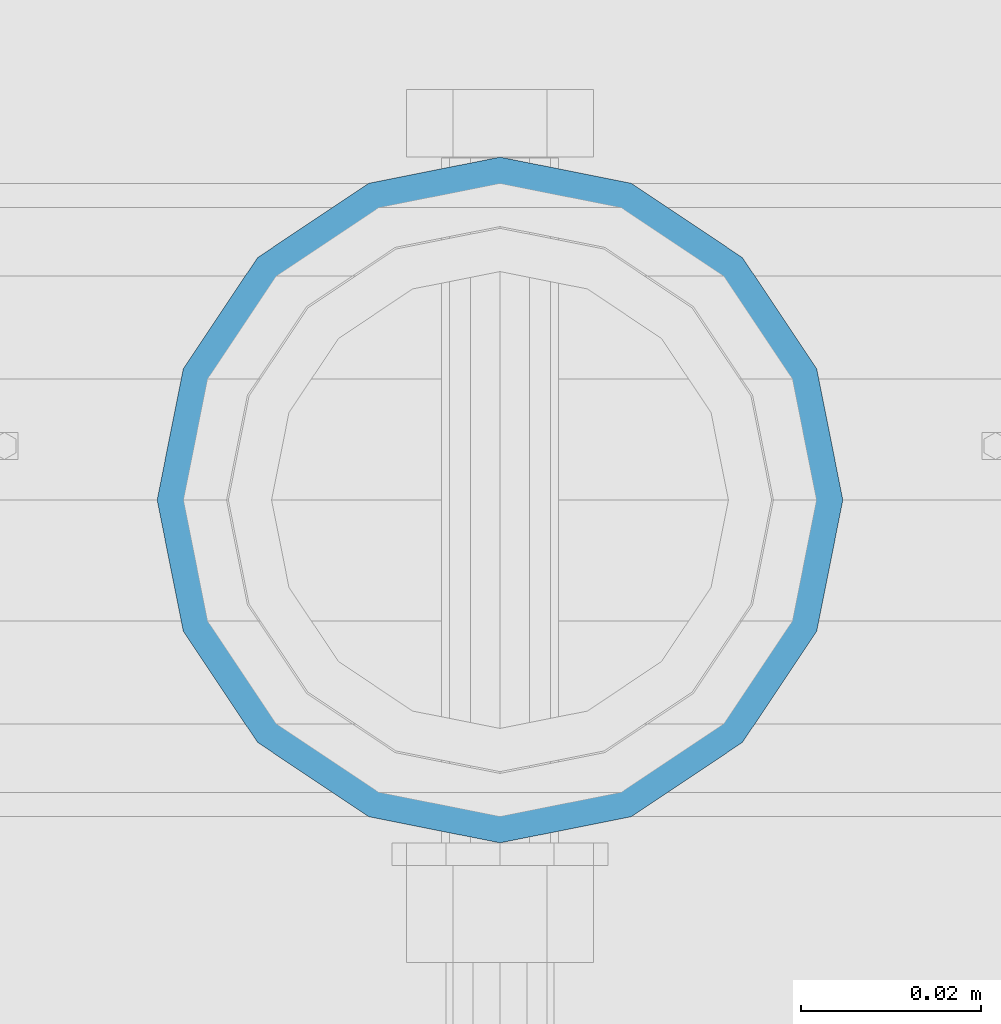
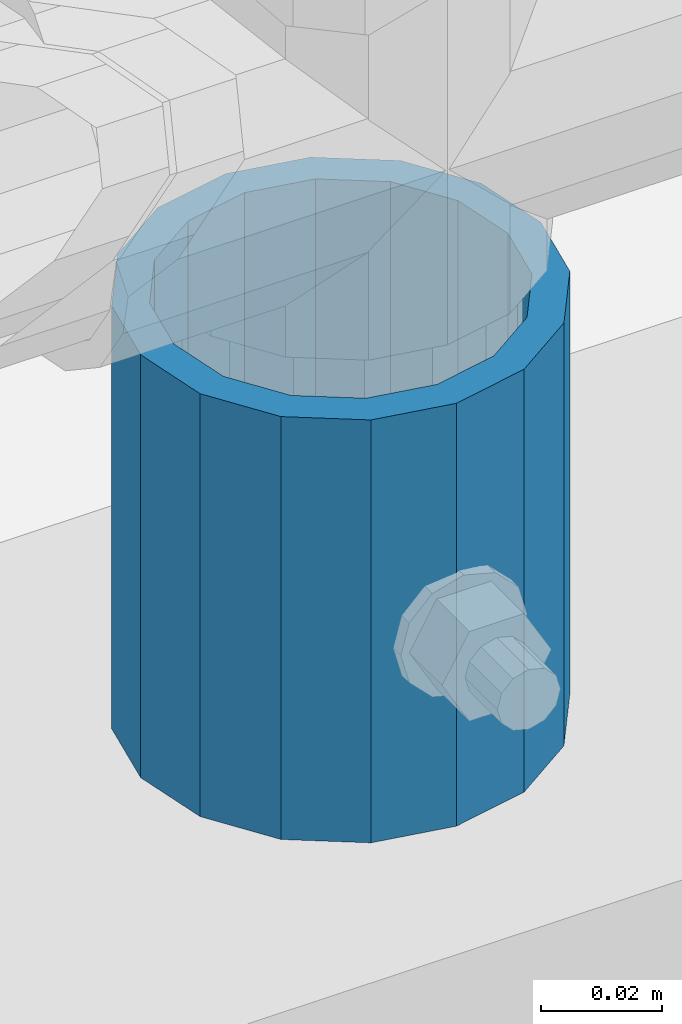
# One storey, part 93 of 242: 1 column.
"""IFC2X3 building model written with IfcOpenShell, lengths in millimetres."""

from ifc_helpers import new_model, si_unit, frame, origin_with_axes, place, context, subcontext, project, spatial, faceted_brep, material, type_object, element, save


model = new_model("IFC2X3")

# Units and contexts
model_context = context("Model", 3, precision=1e-05, world=origin_with_axes())
body_context = subcontext(model_context, "Body", "Model", "MODEL_VIEW")
ifc_project = project(units=[si_unit("LENGTHUNIT", "METRE", prefix="MILLI"), si_unit("AREAUNIT", "SQUARE_METRE"), si_unit("VOLUMEUNIT", "CUBIC_METRE"), si_unit("MASSUNIT", "GRAM", prefix="KILO"), si_unit("TIMEUNIT", "SECOND"), si_unit("PLANEANGLEUNIT", "RADIAN"), si_unit("SOLIDANGLEUNIT", "STERADIAN"), si_unit("THERMODYNAMICTEMPERATUREUNIT", "DEGREE_CELSIUS"), si_unit("LUMINOUSINTENSITYUNIT", "LUMEN")], contexts=[model_context])

# Site, building, storey
site_placement = place(None, origin_with_axes())
site = spatial("IfcSite", under=ifc_project, at=site_placement, CompositionType="ELEMENT")
building_placement = place(site_placement, origin_with_axes())
building = spatial("IfcBuilding", under=site, at=building_placement, Name="Standard", CompositionType="ELEMENT")
storey_placement = place(building_placement, origin_with_axes())
storey = spatial("IfcBuildingStorey", under=building, at=storey_placement, Name="Undefined", CompositionType="ELEMENT", Elevation=0.0)

# Column
ifc_material = material()
column_type = type_object("IfcColumnType", PredefinedType="NOTDEFINED")
column_placement = place(storey_placement, frame((-28765.0, -19335.5, 168.02), z_axis=(0.0, 1.0, 0.0), x_axis=(0.0, 0.0, 1.0)))
element("IfcColumn", 1, at=column_placement, inside=storey, type_object=column_type, material=ifc_material, context=body_context, shape_type="Brep", body=[
    faceted_brep([(0.0, -31.75, 0.0), (0.0, -29.3331751572332, 12.1501989775934), (85.0, -29.3331751572332, 12.1501989775934), (85.0, -31.75, 0.0), (0.0, -22.4506403026717, 22.4506403026717), (85.0, -22.4506403026717, 22.4506403026717), (0.0, -12.1501989775934, 29.3331751572332), (85.0, -12.1501989775934, 29.3331751572332), (0.0, 0.0, 31.75), (85.0, 0.0, 31.75), (0.0, 12.1501989775934, 29.3331751572332), (85.0, 12.1501989775934, 29.3331751572332), (0.0, 22.4506403026717, 22.4506403026717), (85.0, 22.4506403026717, 22.4506403026717), (0.0, 29.3331751572332, 12.1501989775934), (85.0, 29.3331751572332, 12.1501989775934), (0.0, 31.75, 0.0), (85.0, 31.75, 0.0), (0.0, 29.3331751572332, -12.1501989775934), (85.0, 29.3331751572332, -12.1501989775934), (0.0, 22.4506403026717, -22.4506403026717), (85.0, 22.4506403026717, -22.4506403026717), (0.0, 12.1501989775934, -29.3331751572332), (85.0, 12.1501989775934, -29.3331751572332), (0.0, 0.0, -31.75), (85.0, 0.0, -31.75), (0.0, -12.1501989775934, -29.3331751572332), (85.0, -12.1501989775934, -29.3331751572332), (0.0, -22.4506403026717, -22.4506403026717), (85.0, -22.4506403026717, -22.4506403026717), (0.0, -29.3331751572332, -12.1501989775934), (85.0, -29.3331751572332, -12.1501989775934), (0.0, -38.0499999999993, 0.0), (0.0, -35.1536162120537, -14.5611046014928), (85.0, -35.1536162120537, -14.5611046014928), (85.0, -38.0499999999993, 0.0), (0.0, -26.9054130241493, -26.9054130241493), (85.0, -26.9054130241493, -26.9054130241493), (0.0, -14.5611046014928, -35.1536162120537), (85.0, -14.5611046014928, -35.1536162120537), (0.0, 0.0, -38.0499999999993), (85.0, 0.0, -38.0499999999993), (0.0, 14.5611046014928, -35.1536162120537), (85.0, 14.5611046014928, -35.1536162120537), (0.0, 26.9054130241493, -26.9054130241493), (85.0, 26.9054130241493, -26.9054130241493), (0.0, 35.1536162120537, -14.5611046014928), (85.0, 35.1536162120537, -14.5611046014928), (0.0, 38.0499999999993, 0.0), (85.0, 38.0499999999993, 0.0), (0.0, 35.1536162120537, 14.5611046014928), (85.0, 35.1536162120537, 14.5611046014928), (0.0, 26.9054130241493, 26.9054130241493), (85.0, 26.9054130241493, 26.9054130241493), (0.0, 14.5611046014928, 35.1536162120537), (85.0, 14.5611046014928, 35.1536162120537), (0.0, 0.0, 38.0499999999993), (85.0, 0.0, 38.0499999999993), (0.0, -14.5611046014928, 35.1536162120537), (85.0, -14.5611046014928, 35.1536162120537), (0.0, -26.9054130241493, 26.9054130241493), (85.0, -26.9054130241493, 26.9054130241493), (0.0, -35.1536162120537, 14.5611046014928), (85.0, -35.1536162120537, 14.5611046014928)], [[[0, 1, 2, 3]], [[1, 4, 5, 2]], [[4, 6, 7, 5]], [[6, 8, 9, 7]], [[8, 10, 11, 9]], [[10, 12, 13, 11]], [[12, 14, 15, 13]], [[14, 16, 17, 15]], [[16, 18, 19, 17]], [[18, 20, 21, 19]], [[20, 22, 23, 21]], [[22, 24, 25, 23]], [[24, 26, 27, 25]], [[26, 28, 29, 27]], [[28, 30, 31, 29]], [[30, 0, 3, 31]], [[32, 33, 34, 35]], [[33, 36, 37, 34]], [[36, 38, 39, 37]], [[38, 40, 41, 39]], [[40, 42, 43, 41]], [[42, 44, 45, 43]], [[44, 46, 47, 45]], [[46, 48, 49, 47]], [[48, 50, 51, 49]], [[50, 52, 53, 51]], [[52, 54, 55, 53]], [[54, 56, 57, 55]], [[56, 58, 59, 57]], [[58, 60, 61, 59]], [[60, 62, 63, 61]], [[62, 32, 35, 63]], [[37, 39, 41, 43, 45, 47, 49, 51, 53, 55, 57, 59, 61, 63, 35, 34], [5, 7, 9, 11, 13, 15, 17, 19, 21, 23, 25, 27, 29, 31, 3, 2]], [[62, 60, 58, 56, 54, 52, 50, 48, 46, 44, 42, 40, 38, 36, 33, 32], [30, 28, 26, 24, 22, 20, 18, 16, 14, 12, 10, 8, 6, 4, 1, 0]]]),
])

save(model, "model.ifc")
